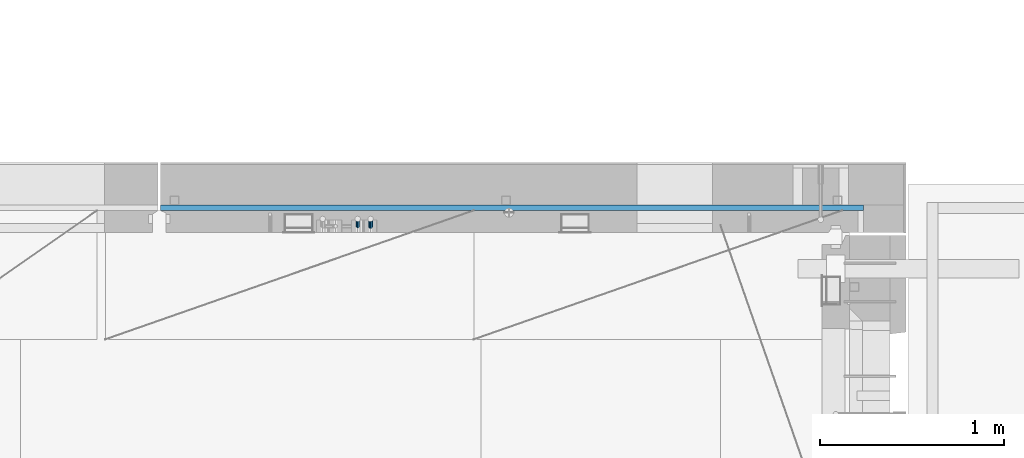
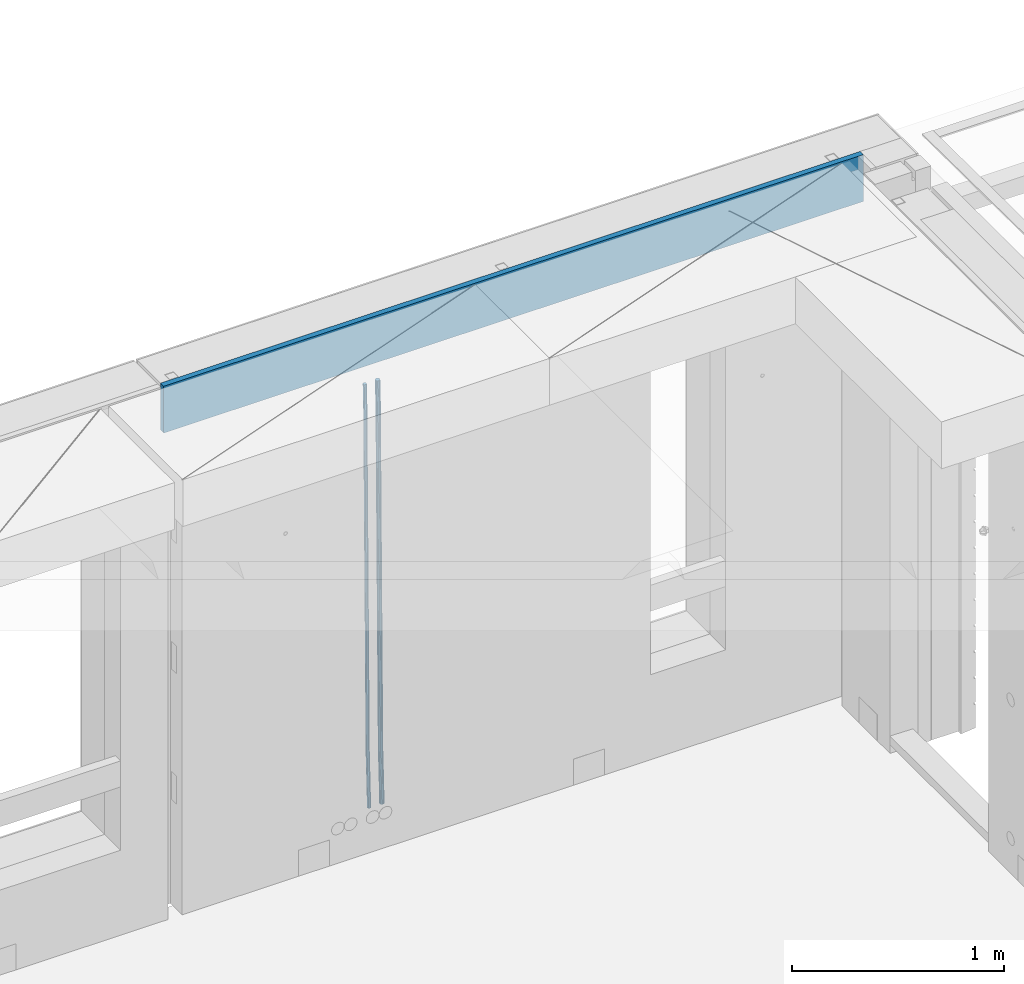
# One storey, part 110 of 325: 3 beams, 1 element without a shape of its own.
"""IFC2X3 building model written with IfcOpenShell, lengths in millimetres."""

import ifcopenshell
import ifcopenshell.guid

model = None  # the IFC model being written
_history = None  # IfcOwnerHistory: only IFC2X3 demands one
_inside = {}  # id of a spatial element -> (the spatial element, [elements in it])
_under = {}  # id of a project, library or spatial element -> (it, [spatial elements below it])
_declared = {}  # id of a project -> (the project, [libraries it declares])
_typed = {}  # id of a type object -> (the type object, [elements of that type])
_made_of = {}  # id of a material, layer set ... -> (it, [elements and type objects made of it])


def new_model(schema):
    """Start an empty IFC model of exactly this schema.

    Asked for "IFC4X3", IfcOpenShell would pick the latest addendum, in which some entities
    have other attributes; the version numbers below select the first issue.
    IFC2X3 requires an IfcOwnerHistory on every rooted entity: one is made here for all.
    """
    global model, _history
    if schema == "IFC4X3":
        model = ifcopenshell.file(schema_version=(4, 3, 0, 0))
    else:
        model = ifcopenshell.file(schema=schema)
    _inside.clear()
    _under.clear()
    _declared.clear()
    _typed.clear()
    _made_of.clear()
    _history = None
    if model.schema == "IFC2X3":
        org = make("IfcOrganization", Name="unknown")
        user = make(
            "IfcPersonAndOrganization",
            ThePerson=make("IfcPerson", FamilyName="unknown"),
            TheOrganization=org,
        )
        app = make(
            "IfcApplication",
            ApplicationDeveloper=org,
            Version="unknown",
            ApplicationFullName="unknown",
            ApplicationIdentifier="unknown",
        )
        _history = make(
            "IfcOwnerHistory",
            OwningUser=user,
            OwningApplication=app,
            ChangeAction="ADDED",
            CreationDate=0,
        )
    return model


def make(cls, **values):
    """One entity of the class cls with the attributes given. An attribute that is None is left unset."""
    return model.create_entity(
        cls, **{name: value for name, value in values.items() if value is not None}
    )


def rooted(cls, **values):
    """An entity with a GlobalId (a new one), such as an element, a storey or a relation."""
    return make(cls, GlobalId=ifcopenshell.guid.new(), OwnerHistory=_history, **values)


def si_unit(unit_type, name, prefix=None):
    """IfcSIUnit, for example si_unit("LENGTHUNIT", "METRE", prefix="MILLI")."""
    return make("IfcSIUnit", UnitType=unit_type, Prefix=prefix, Name=name)


def assignment(units):
    """IfcUnitAssignment: the units of a project."""
    return None if units is None else make("IfcUnitAssignment", Units=units)


def point(xyz):
    """IfcCartesianPoint."""
    return None if xyz is None else make("IfcCartesianPoint", Coordinates=xyz)


def direction(xyz):
    """IfcDirection."""
    return None if xyz is None else make("IfcDirection", DirectionRatios=xyz)


def frame(location, z_axis=None, x_axis=None):
    """IfcAxis2Placement3D, a coordinate frame: its origin and axes. An axis left out is left unset."""
    return make(
        "IfcAxis2Placement3D",
        Location=point(location),
        Axis=direction(z_axis),
        RefDirection=direction(x_axis),
    )


def origin_with_axes():
    """The frame at (0, 0, 0) with the z axis (0, 0, 1) and the x axis (1, 0, 0) written out."""
    return frame((0.0, 0.0, 0.0), z_axis=(0.0, 0.0, 1.0), x_axis=(1.0, 0.0, 0.0))


def place(relative_to, where):
    """IfcLocalPlacement: puts the frame where relative to a parent placement (None: the world)."""
    return make(
        "IfcLocalPlacement", PlacementRelTo=relative_to, RelativePlacement=where
    )


def context(
    kind, dimensions, precision=None, world=None, true_north=None, identifier=None
):
    """IfcGeometricRepresentationContext, for example the 3D "Model" context."""
    return make(
        "IfcGeometricRepresentationContext",
        ContextIdentifier=identifier,
        ContextType=kind,
        CoordinateSpaceDimension=dimensions,
        Precision=precision,
        WorldCoordinateSystem=world,
        TrueNorth=true_north,
    )


def subcontext(parent, identifier, kind, view, scale=None):
    """IfcGeometricRepresentationSubContext, for example "Body" below "Model"."""
    return make(
        "IfcGeometricRepresentationSubContext",
        ContextIdentifier=identifier,
        ContextType=kind,
        ParentContext=parent,
        TargetScale=scale,
        TargetView=view,
    )


def project(units=None, contexts=None):
    """IfcProject with its units and contexts."""
    return rooted(
        "IfcProject",
        Name="project",
        RepresentationContexts=contexts,
        UnitsInContext=assignment(units),
    )


def spatial(cls, under=None, at=None, **own):
    """A site, building, storey or space (cls), placed at a placement, below another one or the project."""
    s = rooted(cls, ObjectPlacement=at, **own)
    if under is not None:
        _under.setdefault(under.id(), (under, []))[1].append(s)
    return s


def faces_of(points, faces, orient=None, outer=None):
    """IfcFace entities. A face is a list of loops; a loop is a list of indices into points, from 0.

    orient and outer hold one flag for each loop. By default every Orientation is true, the
    first loop of a face is its IfcFaceOuterBound and the others are IfcFaceBound.
    """
    made = []
    for i, loops in enumerate(faces):
        bounds = []
        for j, loop in enumerate(loops):
            is_outer = j == 0 if outer is None else outer[i][j]
            bounds.append(
                make(
                    "IfcFaceOuterBound" if is_outer else "IfcFaceBound",
                    Bound=make("IfcPolyLoop", Polygon=[points[k] for k in loop]),
                    Orientation=True if orient is None else orient[i][j],
                )
            )
        made.append(make("IfcFace", Bounds=bounds))
    return made


def faceted_brep(points, faces, orient=None, outer=None, voids=None):
    """IfcFacetedBrep: a solid bounded by flat faces; with voids (closed shells), ...WithVoids."""
    shared = [point(p) for p in points]
    hull = make("IfcClosedShell", CfsFaces=faces_of(shared, faces, orient, outer))
    if voids is None:
        return make("IfcFacetedBrep", Outer=hull)
    return make(
        "IfcFacetedBrepWithVoids",
        Outer=hull,
        Voids=[
            make(cls, CfsFaces=faces_of(shared, fs, o, b)) for cls, fs, o, b in voids
        ],
    )


def shape(context_of_items, identifier, shape_type, items):
    """IfcShapeRepresentation: the items that make up one representation, for example the "Body"."""
    return make(
        "IfcShapeRepresentation",
        ContextOfItems=context_of_items,
        RepresentationIdentifier=identifier,
        RepresentationType=shape_type,
        Items=items,
    )


def material(Name=None, Category=None):
    """IfcMaterial."""
    return make("IfcMaterial", Name=Name, Category=Category)


def made_of(thing, what):
    """Note that an element or type object is made of a material, layer set ...; save() writes the relation."""
    if what is not None:
        _made_of.setdefault(what.id(), (what, []))[1].append(thing)
    return thing


def type_object(cls, material=None, **own):
    """A type object (cls), such as IfcWallType, which elements share."""
    return made_of(rooted(cls, **own), material)


def element(
    cls,
    number,
    at=None,
    inside=None,
    cuts=None,
    type_object=None,
    material=None,
    context=None,
    identifier="Body",
    shape_type=None,
    held_by="IfcProductDefinitionShape",
    body=None,
    shapes=None,
    **own,
):
    """One element of the class cls, such as IfcWall. Its Tag is "e" and its number.

    at: its placement. inside: the storey or other place that contains it. cuts: it is an
    opening in that element (IfcRelVoidsElement). A single representation is given by context,
    identifier, shape_type and body (its items); several are given by shapes. held_by: the class
    of the entity that holds the representations. save() writes the other relations.
    """
    e = rooted(cls, Tag="e%d" % number, ObjectPlacement=at, **own)
    if body is not None:
        shapes = [shape(context, identifier, shape_type, body)]
    if shapes is not None:
        e.Representation = make(held_by, Representations=shapes)
    if inside is not None:
        _inside.setdefault(inside.id(), (inside, []))[1].append(e)
    if cuts is not None:
        rooted(
            "IfcRelVoidsElement", RelatingBuildingElement=cuts, RelatedOpeningElement=e
        )
    if type_object is not None:
        _typed.setdefault(type_object.id(), (type_object, []))[1].append(e)
    return made_of(e, material)


def aggregate(whole, parts):
    """IfcRelAggregates: a whole, such as a stair, and the parts it consists of."""
    return rooted("IfcRelAggregates", RelatingObject=whole, RelatedObjects=parts)


def save(model, path):
    """Write the relations noted so far, then the file.

    IfcRelAggregates (storeys below a building ...), IfcRelContainedInSpatialStructure (elements
    in a storey), IfcRelDefinesByType, IfcRelAssociatesMaterial and IfcRelDeclares: one each for
    every whole, place, type object, material and project.
    """
    for whole, parts in _under.values():
        aggregate(whole, parts)
    for where, things in _inside.values():
        rooted(
            "IfcRelContainedInSpatialStructure",
            RelatedElements=things,
            RelatingStructure=where,
        )
    for kind, things in _typed.values():
        rooted("IfcRelDefinesByType", RelatedObjects=things, RelatingType=kind)
    for what, things in _made_of.values():
        rooted("IfcRelAssociatesMaterial", RelatedObjects=things, RelatingMaterial=what)
    for by, libraries in _declared.values():
        rooted("IfcRelDeclares", RelatingContext=by, RelatedDefinitions=libraries)
    model.write(path)


model = new_model("IFC2X3")

# Units and contexts
model_context = context("Model", 3, precision=1e-05, world=origin_with_axes())
body_context = subcontext(model_context, "Body", "Model", "MODEL_VIEW")
ifc_project = project(units=[si_unit("LENGTHUNIT", "METRE", prefix="MILLI"), si_unit("AREAUNIT", "SQUARE_METRE"), si_unit("VOLUMEUNIT", "CUBIC_METRE"), si_unit("MASSUNIT", "GRAM", prefix="KILO"), si_unit("TIMEUNIT", "SECOND"), si_unit("PLANEANGLEUNIT", "RADIAN"), si_unit("SOLIDANGLEUNIT", "STERADIAN"), si_unit("THERMODYNAMICTEMPERATUREUNIT", "DEGREE_CELSIUS"), si_unit("LUMINOUSINTENSITYUNIT", "LUMEN")], contexts=[model_context])

# Site, building, storey
site_placement = place(None, origin_with_axes())
site = spatial("IfcSite", under=ifc_project, at=site_placement, CompositionType="ELEMENT")
building_placement = place(site_placement, origin_with_axes())
building = spatial("IfcBuilding", under=site, at=building_placement, CompositionType="ELEMENT")
storey_placement = place(building_placement, origin_with_axes())
storey = spatial("IfcBuildingStorey", under=building, at=storey_placement, Name="1", CompositionType="ELEMENT", Elevation=0.0)

# Assembly, beams
assembly_placement = place(storey_placement, origin_with_axes())
assembly = element("IfcElementAssembly", 1, at=assembly_placement, inside=storey, AssemblyPlace="NOTDEFINED", PredefinedType="REINFORCEMENT_UNIT")
ifc_material_1 = material()
beam_type_1 = type_object("IfcBeamType", Name="D20", PredefinedType="NOTDEFINED")
beam_1_placement = place(assembly_placement, frame((28790.0000000039, 22654.9999977209, 81990.0), z_axis=(-0.000205762999925498, 0.999642804629538, -0.0267249099901004), x_axis=(4.30000201928125e-08, 0.0267249099948059, 0.999642825806181)))
beam_1 = element("IfcBeam", 2, at=beam_1_placement, type_object=beam_type_1, material=ifc_material_1, Name="JM20", ObjectType="D20", context=body_context, shape_type="Brep", body=[
    faceted_brep([(0.0, -10.0, 0.0), (-4.19531716033816e-08, -7.07106781186667, -7.07106781187031), (60.4266690400545, -7.0710677960451, -7.07106780570757), (60.4266690441291, -9.99999998418934, 6.15546014159918e-09), (0.0, 0.0, -10.0), (60.426669036824, 1.58106558956206e-08, -9.99999999384454), (4.196772351861e-08, 7.07106781186303, -7.07106781186667), (60.4266690363438, 7.07106782768096, -7.07106780570757), (0.0, 10.0, 0.0), (60.4266690388904, 10.0000000158179, 6.15182216279209e-09), (4.196772351861e-08, 7.07106781185939, 7.07106781185939), (60.4266690429649, 7.07106782768096, 7.07106781802577), (0.0, 0.0, 10.0), (60.4266690461809, 1.58179318532348e-08, 10.0000000061555), (-4.19531716033816e-08, -7.07106781187031, 7.07106781185939), (60.4266690466611, -7.07106779605238, 7.07106781802213), (61.0378400410118, -7.07106779588503, -7.07106780564936), (60.991799419251, -9.99999998403655, 6.21366780251265e-09), (61.0569027789461, 1.5985278878361e-08, -9.99999999378269), (61.0378209396877, 7.07106782784831, -7.07106780564936), (60.9917724058905, 10.0000000159635, 6.21366780251265e-09), (60.9457317841297, 7.07106782781193, 7.0710678180767), (60.9266690461809, 1.59488990902901e-08, 10.0000000062028), (60.9457508854539, -7.07106779591413, 7.0710678180767), (61.6489592143771, -7.07106614513759, -7.06310863441468), (61.5568818710308, -9.9999984576425, 0.00735959856683621), (61.6870830769039, 1.71821739058942e-06, -9.99179257185824), (61.6489210170112, 7.07106947854481, -7.06310888312146), (61.556827851804, 10.0000015422847, 0.00735924683976918), (61.4647505084577, 7.07106922979438, 7.07782747982128), (61.4266266459163, 1.36643211590126e-06, 10.0065114172685), (61.464788705809, -7.07106639389531, 7.07782772852806), (176.543135720174, -7.07075579406956, -5.56673531796696), (176.451058376813, -9.99968810657447, 1.50373291501455), (176.581259582701, 0.000312069292704109, -8.49541925541052), (176.543097522794, 7.07137982961285, -5.56673556667374), (176.451004357587, 10.00031189336, 1.50373256329476), (176.35892701424, 7.07137958085514, 8.57420079627263), (176.320803151699, 0.000311717507429421, 11.5028847337162), (176.358965211621, -7.07075604281999, 8.57420104497578), (177.098753836006, -7.07075429323595, -5.55949898843028), (176.98362511232, -9.99968666800123, 1.510669025065), (177.146421932586, 0.000313595905026887, -8.48805862247536), (177.098706077581, 7.07138133041735, -5.55949936166144), (176.983557571715, 10.0003133318824, 1.51066849724157), (176.868428848029, 7.07138095712435, 8.58083651073321), (176.820760751449, 0.000313067976094317, 11.5093961447819), (176.868476606425, -7.07075466652896, 8.58083688396073), (177.654312950661, -7.07075204110879, -5.54863964998367), (177.516135294456, -9.99968450931192, 1.52107783331303), (177.711524267797, 0.000315886711177882, -8.47701274570863), (177.654255632195, 7.07138358250813, -5.54864021007961), (177.516054233929, 10.0003154905207, 1.5210770412159), (177.377876577739, 7.0713830223176, 8.59079452451624), (177.320665260588, 0.000315094497636892, 11.5191676202448), (177.377933896176, -7.07075260129932, 8.59079508461218), (299.436796249574, -7.07025836271714, -3.1681962331204), (299.298618593355, -9.99919083092027, 3.90152125031091), (299.494007566798, 0.000809565110102994, -6.09656932889993), (299.436738931283, 7.07187726089978, -3.16819679320906), (299.298537533061, 10.0008091689197, 3.90152045822106), (299.160359876842, 7.07187670072017, 10.9712379416487), (299.103148559603, 0.000808772889286047, 13.8996110374392), (299.160417195119, -7.07025892290039, 10.9712385017483), (299.98743051647, -7.07025613056248, -3.15743315966392), (299.971788958996, -9.99918809853989, 3.91467979818117), (299.993912075952, 0.000811591617093654, -6.08679785393178), (299.987423933868, 7.07187949325817, -3.1574327280432), (299.971753863239, 10.0008119014747, 3.91467990454839), (299.95611230444, 7.07187992653053, 10.9867922621015), (299.949630744944, 0.000812204350950196, 13.9161569563694), (299.956118887014, -7.07025569729012, 10.9867918304735), (300.538107039494, -7.07025785017686, -3.16575821840888), (300.644985195438, -9.99919020432935, 3.90450175465594), (300.493854948218, 0.000810030429420294, -6.09435592770024), (300.538151196495, 7.071877773491, -3.16575855385963), (300.645047642858, 10.0008097955724, 3.90450128024895), (300.751925798773, 7.07187744142357, 10.9747612533101), (300.796177890064, 0.000809560813650023, 13.9033589625978), (300.751881641787, -7.07025818224065, 10.9747615887682), (2293.36490490142, -7.07648090940347, -33.2930642912361), (2293.47178305736, -10.0054132635523, -26.2228043181785), (2293.32065281013, -0.00541302880083094, -36.2216620005347), (2293.36494905842, 7.06565471425711, -33.2930646266868), (2293.47184550477, 9.99458673634581, -26.2228047925819), (2293.57872366071, 7.06565438219332, -19.1525448195243), (2293.62297575199, -0.00541349841296324, -16.2239471102366), (2293.57867950371, -7.0764812414709, -19.1525444840736), (2294.0658245362, -7.07648309818615, -33.3036607065333), (2294.05312277409, -10.0054150789219, -26.2315929392535), (2294.10928714235, -0.00541549149056664, -36.2335844756526), (2294.15805078732, 7.06565223761572, -33.3050546393533), (2294.18355038921, 9.99458451388637, -26.2335642579346), (2294.17084862708, 7.06565253314329, -19.1614964906439), (2294.12738602093, -0.00541507354500936, -16.2315727215355), (2294.07862237596, -7.07648280265857, -19.1601025578348), (2294.76670261032, -7.08562269121467, -33.294332712383), (2294.63442802057, -10.0129954178956, -26.2238563411993), (2294.89787471293, -0.0156988342423574, -36.2230891548279), (2294.95110548967, 7.05531064255774, -33.2944998654275), (2294.89521307347, 9.98530428734011, -26.2240927312887), (2294.76293848372, 7.0579315606592, -19.1536163601049), (2294.63176638114, -0.0119922963167483, -16.2248599176673), (2294.57853560438, -7.08300177311321, -19.1534492070678), (2316.52657204497, -7.36937582653991, -33.0047303660212), (2316.39429745522, -10.2967485532172, -25.9342539948302), (2316.65774414754, -0.299451969567599, -35.9334868084661), (2316.7109749243, 6.7715575072325, -33.0048975190657), (2316.65508250811, 9.70155115201487, -25.9344903849269), (2316.52280791836, 6.7741784253376, -18.8640140137468), (2316.39163581574, -0.295745431634714, -15.9352575713092), (2316.33840503903, -7.36675490843481, -18.863846860706), (2317.16202064224, -7.37766220584308, -32.9962731735213), (2317.05438744847, -10.3053562613532, -25.9254688497131), (2317.23607125619, -0.306993473008333, -35.925789846493), (2317.23316144495, 6.76474808850253, -32.9979477328052), (2317.15499573652, 9.6950321815566, -25.9278370341635), (2317.04736254275, 6.7673381260538, -18.8570327103698), (2316.97331192881, -0.303330606784584, -15.9275160373909), (2316.97622174003, -7.37507216829545, -18.8553581510787), (2317.79752306276, -7.37578610372293, -32.9880110666527), (2317.71453320107, -10.3033876998124, -25.9168792378296), (2317.81444760226, -0.305295583297266, -35.918287695793), (2317.75539265381, 6.76628640723357, -32.9911928173897), (2317.65495180529, 9.69652304524061, -25.9213789128698), (2317.5719619436, 6.76892144914746, -18.8502470840467), (2317.55503740412, -0.301569071270933, -15.9199704549137), (2317.61409235255, -7.3731510618054, -18.847065333317), (2417.8183084176, -7.07752398473531, -31.6906369377139), (2417.73531855589, -10.0051255808248, -24.6195051088798), (2417.83523295709, -0.007033464313281, -34.6209135668432), (2417.77617800863, 7.06454852621755, -31.6938186884508), (2417.67573716014, 9.99478516423187, -24.6240047839383), (2417.59274729842, 7.06718356813872, -17.5528729551006), (2417.57582275895, -0.00330695228694822, -14.6225963259749), (2417.6348777074, -7.07488894281778, -17.5496912043673)], [[[0, 1, 2, 3]], [[1, 4, 5, 2]], [[4, 6, 7, 5]], [[6, 8, 9, 7]], [[8, 10, 11, 9]], [[10, 12, 13, 11]], [[12, 14, 15, 13]], [[14, 0, 3, 15]], [[14, 12, 10, 8, 6, 4, 1, 0]], [[3, 2, 16, 17]], [[2, 5, 18, 16]], [[5, 7, 19, 18]], [[7, 9, 20, 19]], [[9, 11, 21, 20]], [[11, 13, 22, 21]], [[13, 15, 23, 22]], [[15, 3, 17, 23]], [[17, 16, 24, 25]], [[16, 18, 26, 24]], [[18, 19, 27, 26]], [[19, 20, 28, 27]], [[20, 21, 29, 28]], [[21, 22, 30, 29]], [[22, 23, 31, 30]], [[23, 17, 25, 31]], [[25, 24, 32, 33]], [[24, 26, 34, 32]], [[26, 27, 35, 34]], [[27, 28, 36, 35]], [[28, 29, 37, 36]], [[29, 30, 38, 37]], [[30, 31, 39, 38]], [[31, 25, 33, 39]], [[33, 32, 40, 41]], [[32, 34, 42, 40]], [[34, 35, 43, 42]], [[35, 36, 44, 43]], [[36, 37, 45, 44]], [[37, 38, 46, 45]], [[38, 39, 47, 46]], [[39, 33, 41, 47]], [[41, 40, 48, 49]], [[40, 42, 50, 48]], [[42, 43, 51, 50]], [[43, 44, 52, 51]], [[44, 45, 53, 52]], [[45, 46, 54, 53]], [[46, 47, 55, 54]], [[47, 41, 49, 55]], [[49, 48, 56, 57]], [[48, 50, 58, 56]], [[50, 51, 59, 58]], [[51, 52, 60, 59]], [[52, 53, 61, 60]], [[53, 54, 62, 61]], [[54, 55, 63, 62]], [[55, 49, 57, 63]], [[57, 56, 64, 65]], [[56, 58, 66, 64]], [[58, 59, 67, 66]], [[59, 60, 68, 67]], [[60, 61, 69, 68]], [[61, 62, 70, 69]], [[62, 63, 71, 70]], [[63, 57, 65, 71]], [[65, 64, 72, 73]], [[64, 66, 74, 72]], [[66, 67, 75, 74]], [[67, 68, 76, 75]], [[68, 69, 77, 76]], [[69, 70, 78, 77]], [[70, 71, 79, 78]], [[71, 65, 73, 79]], [[73, 72, 80, 81]], [[72, 74, 82, 80]], [[74, 75, 83, 82]], [[75, 76, 84, 83]], [[76, 77, 85, 84]], [[77, 78, 86, 85]], [[78, 79, 87, 86]], [[79, 73, 81, 87]], [[81, 80, 88, 89]], [[80, 82, 90, 88]], [[82, 83, 91, 90]], [[83, 84, 92, 91]], [[84, 85, 93, 92]], [[85, 86, 94, 93]], [[86, 87, 95, 94]], [[87, 81, 89, 95]], [[89, 88, 96, 97]], [[88, 90, 98, 96]], [[90, 91, 99, 98]], [[91, 92, 100, 99]], [[92, 93, 101, 100]], [[93, 94, 102, 101]], [[94, 95, 103, 102]], [[95, 89, 97, 103]], [[97, 96, 104, 105]], [[96, 98, 106, 104]], [[98, 99, 107, 106]], [[99, 100, 108, 107]], [[100, 101, 109, 108]], [[101, 102, 110, 109]], [[102, 103, 111, 110]], [[103, 97, 105, 111]], [[105, 104, 112, 113]], [[104, 106, 114, 112]], [[106, 107, 115, 114]], [[107, 108, 116, 115]], [[108, 109, 117, 116]], [[109, 110, 118, 117]], [[110, 111, 119, 118]], [[111, 105, 113, 119]], [[113, 112, 120, 121]], [[112, 114, 122, 120]], [[114, 115, 123, 122]], [[115, 116, 124, 123]], [[116, 117, 125, 124]], [[117, 118, 126, 125]], [[118, 119, 127, 126]], [[119, 113, 121, 127]], [[121, 120, 128, 129]], [[120, 122, 130, 128]], [[122, 123, 131, 130]], [[123, 124, 132, 131]], [[124, 125, 133, 132]], [[125, 126, 134, 133]], [[126, 127, 135, 134]], [[127, 121, 129, 135]], [[130, 131, 132, 133, 134, 135, 129, 128]]]),
])
beam_type_2 = type_object("IfcBeamType", Name="D25", PredefinedType="NOTDEFINED")
beam_2_placement = place(assembly_placement, frame((28860.0000000039, 22654.9999977209, 81990.0), z_axis=(-0.000205762999925498, 0.999642804629538, -0.0267249099901004), x_axis=(4.30000201928125e-08, 0.0267249099948059, 0.999642825806181)))
beam_2 = element("IfcBeam", 3, at=beam_2_placement, type_object=beam_type_2, material=ifc_material_1, Name="JM25", ObjectType="D25", context=body_context, shape_type="Brep", body=[
    faceted_brep([(-7.41420080885291e-08, -12.5, -3.63797880709171e-12), (-6.42030499875546e-08, -10.8253175473074, -6.25000000000364), (60.4103898235917, -10.8253175318459, -6.2499999938409), (60.4103898269532, -12.4999999845422, 6.16273609921336e-09), (-3.70782800018787e-08, -6.25000000000364, -10.8253175473074), (60.4103898202884, -6.24999998454587, -10.8253175411446), (-1.45519152283669e-11, -3.63797880709171e-12, -12.5), (60.4103898179019, 1.54577719513327e-08, -12.4999999938373), (3.70637280866504e-08, 6.25, -10.8253175473074), (60.410389817087, 6.25000001545777, -10.825317541141), (6.42030499875546e-08, 10.8253175473001, -6.25000000000364), (60.410389818062, 10.8253175627578, -6.24999999383726), (7.41420080885291e-08, 12.4999999999927, 0.0), (60.4103898205503, 12.5000000154541, 6.16273609921336e-09), (6.42176019027829e-08, 10.8253175473001, 6.24999999999636), (60.4103898238973, 10.8253175627651, 6.2500000061591), (3.70928319171071e-08, 6.24999999999636, 10.8253175473037), (60.4103898272151, 6.25000001546141, 10.8253175534664), (1.45519152283669e-11, -3.63797880709171e-12, 12.4999999999964), (60.4103898296162, 1.54541339725256e-08, 12.5000000061591), (-3.7049176171422e-08, -6.25000000000364, 10.8253175473001), (60.4103898304165, -6.24999998454587, 10.8253175534701), (-6.41884980723262e-08, -10.8253175473074, 6.25), (60.4103898294561, -10.8253175318459, 6.25000000616637), (61.0324985728803, -10.8253175316895, -6.24999999377542), (60.991802792938, -12.4999999843931, 6.22458173893392e-09), (61.0622854283865, -6.24999998437852, -10.8253175410755), (61.0731819955545, 1.5628756955266e-08, -12.4999999937718), (61.0622685480339, 6.25000001562512, -10.8253175410791), (61.032469335245, 10.8253175629216, -6.24999999377178), (60.9917690322181, 12.5000000156033, 6.22458173893392e-09), (60.9510732522613, 10.8253175629034, 6.25000000621731), (60.9212863967696, 6.25000001558874, 10.8253175535247), (60.9103898296162, 1.55814632307738e-08, 12.5000000062137), (60.9213032771368, -6.24999998441126, 10.8253175535174), (60.9511024898966, -10.8253175317113, 6.25000000621731), (61.6545545670233, -10.8253158516927, -6.24189838219536), (61.573166454793, -12.499998414296, 0.00757164385504439), (61.7141257553885, -6.24999822394238, -10.8168280205282), (61.7359179680789, 1.80548886419274e-06, -12.491368569139), (61.7140919992817, 6.25000177601396, -10.8168282403167), (61.6544960997562, 10.8253192428383, -6.2418987628771), (61.5730989426083, 12.5000015856094, 0.0075712042817031), (61.4917108303925, 10.8253190230062, 6.25704123032847), (61.4321396420273, 6.25000139525582, 10.8319708686649), (61.4103474293224, 1.36582457344048e-06, 12.5065114172721), (61.4321733981196, -6.24999860470052, 10.8319710884571), (61.4917692976451, -10.8253160715249, 6.25704161101385), (176.524302641745, -10.8250056210964, -4.74584321979273), (176.442914529529, -12.4996881836996, 1.50362680625403), (176.583873830095, -6.24968799334965, -9.3207728581292), (176.605666042786, 0.000312036081595579, -10.9953134067364), (176.583840074018, 6.25031200660669, -9.32077307791769), (176.524244174492, 10.8256294734347, -4.74584360047811), (176.44284701733, 12.5003118162058, 1.50362636668069), (176.361458905099, 10.8256292535989, 7.75309639272746), (176.301887716749, 6.25031162585219, 12.3280260310676), (176.280095504058, 0.000311596420942806, 14.0025665796711), (176.301921472827, -6.24968837410415, 12.3280262508561), (176.361517372367, -10.8250058409321, 7.75309677341284), (177.085397012124, -10.8250041057399, -4.73853556792164), (176.983633547483, -12.4996867233749, 1.51066909103247), (177.159881729676, -6.24968643771717, -9.31327097355097), (177.187129580227, 0.000313606451527448, -10.987740468332), (177.159839524218, 6.25031356221734, -9.31327130338468), (177.085323910098, 10.8256309887511, -4.73853613920801), (176.983549136537, 12.5003132764905, 1.51066843136869), (176.881785671867, 10.8256306588555, 7.7598730903228), (176.80730095433, 6.25031299082912, 12.3346084959521), (176.780053103794, 0.000312946667690994, 14.0090779907332), (176.807343159802, -6.2496870091054, 12.3346088257895), (176.881858773908, -10.8250044356355, 7.7598736616128), (177.646431799818, -10.8250018318176, -4.72756919822132), (177.524295146417, -12.4996845320202, 1.52123723245313), (177.735828462886, -6.24968410334986, -9.30201312475765), (177.768531371941, 0.00031596292683389, -10.9763759912421), (177.735777808921, 6.25031589654827, -9.30201361973741), (177.646344064575, 10.8256332626152, -4.72757005553649), (177.524193838486, 12.5003154677688, 1.52123624250817), (177.402057185071, 10.8256327675663, 7.77004267317898), (177.312660521988, 6.2503150390985, 12.3444865997226), (177.279957612933, 0.00031497282179771, 14.0188494661961), (177.312711175953, -6.24968496079964, 12.3444870946951), (177.402144920314, -10.8250023268702, 7.77004353049415), (299.377443161706, -10.8245084454466, -2.34813158632096), (299.255306508276, -12.4991911456491, 3.90067484435349), (299.466839824803, -6.24919071697514, -6.92257551286093), (299.499542733873, 0.0008093492979242, -8.59693837933446), (299.466789170867, 6.250809282923, -6.92257600783341), (299.377355426492, 10.8261266489935, -2.34813244364341), (299.255205200388, 12.5008088541435, 3.90067385440125), (299.133068546944, 10.826126153941, 10.1494802850757), (299.043671883861, 6.25080842546959, 14.7239242116229), (299.010968974762, 0.000808359200163977, 16.3982870780892), (299.043722537797, -6.24919157442127, 14.7239247065918), (299.133156282158, -10.8245089404954, 10.1494811423981), (299.98561436501, -10.8245059804758, -2.33624385599614), (299.97179243555, -12.4991882411778, 3.91467976726199), (299.995742293278, -6.24918857328521, -6.91223722345239), (299.999447243041, 0.000811375455668895, -8.58716690387519), (299.995736475976, 6.25081142679483, -6.91223684201032), (299.985604289133, 10.8261291142808, -2.33624319533556), (299.971750386685, 12.5008117588586, 3.91467993563856), (299.957928457196, 10.8261294971744, 10.1656035610831), (299.947800528913, 6.25081208998381, 14.7415969285394), (299.944095579151, 0.00081214124293183, 16.4165266089549), (299.947806346216, -6.24918791008895, 14.7415965471009), (299.957938533058, -10.8245055975785, 10.1656029004225), (300.593832239858, -10.8245078794353, -2.34543881707941), (300.688302931099, -12.4991904788549, 3.90384712594823), (300.524685350189, -6.24919022474205, -6.92023371784308), (300.499390115292, 0.000809814544481924, -8.59472497713432), (300.524724372954, 6.25080977519247, -6.92023401429469), (300.593899829313, 10.8261272150703, -2.34543933054374), (300.688380976673, 12.5008095210287, 3.90384653304136), (300.782851667915, 10.8261269216127, 10.1531324760799), (300.851998557599, 6.25080926691589, 14.7279273768363), (300.877293792495, 0.000809227632998955, 16.4024186361276), (300.851959534804, -6.24919073302226, 14.7279276732806), (300.782784078474, -10.8245081728965, 10.153132989537), (2293.32930409742, -10.8307295605009, -32.4713622331001), (2293.42377478865, -12.5054121599169, -26.2220762900724), (2293.26015720774, -6.2554119058077, -37.0461571338565), (2293.23486197284, -0.00541186651753378, -38.7206483931477), (2293.26019623051, 6.24458809413409, -37.0461574303008), (2293.32937168686, 10.8199055340046, -32.4713627465644), (2293.42385283421, 12.4945878399631, -26.2220768829684), (2293.51832352545, 10.8199052405434, -19.972790939948), (2293.58747041514, 6.24458758585388, -15.3979960391844), (2293.61276565003, -0.00541245343265473, -13.7235047798931), (2293.58743139236, -6.25541241408428, -15.3979957427327), (2293.51825593603, -10.8307298539585, -19.9727904264691), (2294.0420846676, -10.8307317859326, -32.4821379598216), (2294.03681932652, -12.5054140739521, -26.2313442200393), (2294.06778164886, -6.2554144273563, -37.0583666982457), (2294.10702478497, -0.00541458957013674, -38.7338336404937), (2294.14929890928, 6.24458531819619, -37.0595987724118), (2294.18327670435, 10.8199028679592, -32.4842719748667), (2294.1998538474, 12.4945854171456, -26.2338083683717), (2294.19458850632, 10.819903129126, -19.9830146285858), (2294.16889152506, 6.24458577054975, -15.4067858901581), (2294.12964838895, -0.0054140672327776, -13.7313189479173), (2294.08737426462, -6.2554139749991, -15.4055538159919), (2294.05339646956, -10.8307315247621, -19.9808806135297), (2294.75482297382, -10.84002603931, -32.4726521173216), (2294.64982751427, -12.513407826169, -26.2231856868602), (2294.87535820232, -6.26594539088183, -37.0476186524102), (2294.97913588268, -0.0167870967634371, -38.7222267036377), (2295.0383488692, 6.23299192477134, -37.0477663960555), (2295.03713108998, 10.8087684320271, -32.4729080168181), (2294.97580884799, 12.4844668051373, -26.2234811741473), (2294.87081338844, 10.8110850182784, -19.9740147436787), (2294.7502781599, 6.23700436985018, -15.3990482086047), (2294.64650047956, -0.0121539242718427, -13.7244401573698), (2294.58728749304, -6.26193294580662, -15.3989004649666), (2294.58850527227, -10.8377094530588, -19.9737588441894), (2316.44667268227, -11.1228921988077, -32.1839550346631), (2316.34167722271, -12.7962739856739, -25.9344886042054), (2316.56720791078, -6.54881155039038, -36.7589215697517), (2316.67098559113, -0.299653256264719, -38.4335296209792), (2316.73019857766, 5.95012576527006, -36.759069313397), (2316.72898079845, 10.5259022725259, -32.1842109341669), (2316.66765855643, 12.2016006456361, -25.9347840914961), (2316.56266309689, 10.5282188587698, -19.6853176610275), (2316.44212786836, 5.95413821035254, -15.1103511259389), (2316.33835018802, -0.295020083769487, -13.4357430747186), (2316.27913720149, -6.54479910530426, -15.1102033823008), (2316.28035498071, -11.1205756125637, -19.685061761531), (2317.13234804722, -11.1318335458927, -32.1748293731798), (2317.04181141085, -12.8054038787741, -25.9251705100723), (2317.2154741603, -6.5572650749491, -36.7502937866229), (2317.26891617525, -0.307450393454928, -38.4255717558117), (2317.27835434731, 5.94297770185585, -36.7517739018112), (2317.24125972588, 10.5192220504723, -32.1773930078925), (2317.16757178486, 12.1950816748285, -25.9281307404563), (2317.0770351485, 10.5215113419545, -19.6784718773561), (2316.99390903539, 5.94694287101083, -15.1030074639057), (2316.94046702047, -0.302871810494253, -13.4277294947169), (2316.9310288484, -6.55329990579412, -15.1015273487101), (2316.96812346982, -11.1295442544142, -19.6759082426288), (2317.81808136747, -11.1298054502913, -32.1659056455355), (2317.74200467508, -12.803315894289, -25.9160547315114), (2317.86379538118, -6.55536082026447, -36.7418676070083), (2317.8668976831, -0.305700748642266, -38.417815303761), (2317.82655701396, 5.94458339541234, -36.7446799039099), (2317.75358262347, 10.5207330230332, -32.1707766866384), (2317.66752794063, 12.1965725370646, -25.9216793252963), (2317.59145124823, 10.5230620930706, -19.6718284112721), (2317.54573723453, 5.94861746304377, -15.0958664497994), (2317.54263493262, -0.301042608574789, -13.4199187530394), (2317.58297560175, -6.55132675263303, -15.0930541529051), (2317.65594999224, -11.1274763802539, -19.6669573701693), (2417.81884292323, -10.831603083323, -30.8687911350135), (2417.74276623082, -12.505113527317, -24.618940220982), (2417.86455693691, -6.25715845329614, -35.4447530964935), (2417.86765923884, -0.00749838167394046, -37.1207007932499), (2417.82731856969, 6.24278576237703, -35.4475653933878), (2417.75434417921, 10.8189353900088, -30.8736621761236), (2417.66828949639, 12.494774904033, -24.6245648147851), (2417.59221280397, 10.8212644600353, -18.3747139007501), (2417.54649879028, 6.2468198300121, -13.79875193927), (2417.54339648837, -0.00284024161010166, -12.1228042425173), (2417.5837371575, -6.25312438566107, -13.795939642383), (2417.65671154798, -10.8292740132893, -18.3698428596399)], [[[0, 1, 2, 3]], [[1, 4, 5, 2]], [[4, 6, 7, 5]], [[6, 8, 9, 7]], [[8, 10, 11, 9]], [[10, 12, 13, 11]], [[12, 14, 15, 13]], [[14, 16, 17, 15]], [[16, 18, 19, 17]], [[18, 20, 21, 19]], [[20, 22, 23, 21]], [[22, 0, 3, 23]], [[22, 20, 18, 16, 14, 12, 10, 8, 6, 4, 1, 0]], [[3, 2, 24, 25]], [[2, 5, 26, 24]], [[5, 7, 27, 26]], [[7, 9, 28, 27]], [[9, 11, 29, 28]], [[11, 13, 30, 29]], [[13, 15, 31, 30]], [[15, 17, 32, 31]], [[17, 19, 33, 32]], [[19, 21, 34, 33]], [[21, 23, 35, 34]], [[23, 3, 25, 35]], [[25, 24, 36, 37]], [[24, 26, 38, 36]], [[26, 27, 39, 38]], [[27, 28, 40, 39]], [[28, 29, 41, 40]], [[29, 30, 42, 41]], [[30, 31, 43, 42]], [[31, 32, 44, 43]], [[32, 33, 45, 44]], [[33, 34, 46, 45]], [[34, 35, 47, 46]], [[35, 25, 37, 47]], [[37, 36, 48, 49]], [[36, 38, 50, 48]], [[38, 39, 51, 50]], [[39, 40, 52, 51]], [[40, 41, 53, 52]], [[41, 42, 54, 53]], [[42, 43, 55, 54]], [[43, 44, 56, 55]], [[44, 45, 57, 56]], [[45, 46, 58, 57]], [[46, 47, 59, 58]], [[47, 37, 49, 59]], [[49, 48, 60, 61]], [[48, 50, 62, 60]], [[50, 51, 63, 62]], [[51, 52, 64, 63]], [[52, 53, 65, 64]], [[53, 54, 66, 65]], [[54, 55, 67, 66]], [[55, 56, 68, 67]], [[56, 57, 69, 68]], [[57, 58, 70, 69]], [[58, 59, 71, 70]], [[59, 49, 61, 71]], [[61, 60, 72, 73]], [[60, 62, 74, 72]], [[62, 63, 75, 74]], [[63, 64, 76, 75]], [[64, 65, 77, 76]], [[65, 66, 78, 77]], [[66, 67, 79, 78]], [[67, 68, 80, 79]], [[68, 69, 81, 80]], [[69, 70, 82, 81]], [[70, 71, 83, 82]], [[71, 61, 73, 83]], [[73, 72, 84, 85]], [[72, 74, 86, 84]], [[74, 75, 87, 86]], [[75, 76, 88, 87]], [[76, 77, 89, 88]], [[77, 78, 90, 89]], [[78, 79, 91, 90]], [[79, 80, 92, 91]], [[80, 81, 93, 92]], [[81, 82, 94, 93]], [[82, 83, 95, 94]], [[83, 73, 85, 95]], [[85, 84, 96, 97]], [[84, 86, 98, 96]], [[86, 87, 99, 98]], [[87, 88, 100, 99]], [[88, 89, 101, 100]], [[89, 90, 102, 101]], [[90, 91, 103, 102]], [[91, 92, 104, 103]], [[92, 93, 105, 104]], [[93, 94, 106, 105]], [[94, 95, 107, 106]], [[95, 85, 97, 107]], [[97, 96, 108, 109]], [[96, 98, 110, 108]], [[98, 99, 111, 110]], [[99, 100, 112, 111]], [[100, 101, 113, 112]], [[101, 102, 114, 113]], [[102, 103, 115, 114]], [[103, 104, 116, 115]], [[104, 105, 117, 116]], [[105, 106, 118, 117]], [[106, 107, 119, 118]], [[107, 97, 109, 119]], [[109, 108, 120, 121]], [[108, 110, 122, 120]], [[110, 111, 123, 122]], [[111, 112, 124, 123]], [[112, 113, 125, 124]], [[113, 114, 126, 125]], [[114, 115, 127, 126]], [[115, 116, 128, 127]], [[116, 117, 129, 128]], [[117, 118, 130, 129]], [[118, 119, 131, 130]], [[119, 109, 121, 131]], [[121, 120, 132, 133]], [[120, 122, 134, 132]], [[122, 123, 135, 134]], [[123, 124, 136, 135]], [[124, 125, 137, 136]], [[125, 126, 138, 137]], [[126, 127, 139, 138]], [[127, 128, 140, 139]], [[128, 129, 141, 140]], [[129, 130, 142, 141]], [[130, 131, 143, 142]], [[131, 121, 133, 143]], [[133, 132, 144, 145]], [[132, 134, 146, 144]], [[134, 135, 147, 146]], [[135, 136, 148, 147]], [[136, 137, 149, 148]], [[137, 138, 150, 149]], [[138, 139, 151, 150]], [[139, 140, 152, 151]], [[140, 141, 153, 152]], [[141, 142, 154, 153]], [[142, 143, 155, 154]], [[143, 133, 145, 155]], [[145, 144, 156, 157]], [[144, 146, 158, 156]], [[146, 147, 159, 158]], [[147, 148, 160, 159]], [[148, 149, 161, 160]], [[149, 150, 162, 161]], [[150, 151, 163, 162]], [[151, 152, 164, 163]], [[152, 153, 165, 164]], [[153, 154, 166, 165]], [[154, 155, 167, 166]], [[155, 145, 157, 167]], [[157, 156, 168, 169]], [[156, 158, 170, 168]], [[158, 159, 171, 170]], [[159, 160, 172, 171]], [[160, 161, 173, 172]], [[161, 162, 174, 173]], [[162, 163, 175, 174]], [[163, 164, 176, 175]], [[164, 165, 177, 176]], [[165, 166, 178, 177]], [[166, 167, 179, 178]], [[167, 157, 169, 179]], [[169, 168, 180, 181]], [[168, 170, 182, 180]], [[170, 171, 183, 182]], [[171, 172, 184, 183]], [[172, 173, 185, 184]], [[173, 174, 186, 185]], [[174, 175, 187, 186]], [[175, 176, 188, 187]], [[176, 177, 189, 188]], [[177, 178, 190, 189]], [[178, 179, 191, 190]], [[179, 169, 181, 191]], [[181, 180, 192, 193]], [[180, 182, 194, 192]], [[182, 183, 195, 194]], [[183, 184, 196, 195]], [[184, 185, 197, 196]], [[185, 186, 198, 197]], [[186, 187, 199, 198]], [[187, 188, 200, 199]], [[188, 189, 201, 200]], [[189, 190, 202, 201]], [[190, 191, 203, 202]], [[191, 181, 193, 203]], [[194, 195, 196, 197, 198, 199, 200, 201, 202, 203, 193, 192]]]),
])
ifc_material_2 = material(Name="CONCRETE/C25/30")
beam_type_3 = type_object("IfcBeamType", Name="270X30", PredefinedType="NOTDEFINED")
beam_3_placement = place(assembly_placement, frame((31535.0, 22755.0, 84605.0), z_axis=(0.0, 0.0, 1.0), x_axis=(-1.0, 3.00000001838171e-08, 0.0)))
beam_3 = element("IfcBeam", 4, at=beam_3_placement, type_object=beam_type_3, material=ifc_material_2, ObjectType="270X30", context=body_context, shape_type="Brep", body=[
    faceted_brep([(0.0, 15.0, -135.0), (0.0, 15.0, 135.0), (3815.00000000003, 15.0, 135.0), (3815.00000000003, 15.0, -135.0), (0.0, -15.0, 135.0), (3815.00000000003, -15.0, 135.0), (0.0, -15.0, -135.0), (3815.00000000003, -15.0, -135.0)], [[[0, 1, 2, 3]], [[1, 4, 5, 2]], [[4, 6, 7, 5]], [[6, 0, 3, 7]], [[5, 7, 3, 2]], [[6, 4, 1, 0]]]),
])
aggregate(assembly, [beam_1, beam_2, beam_3])

save(model, "model.ifc")
